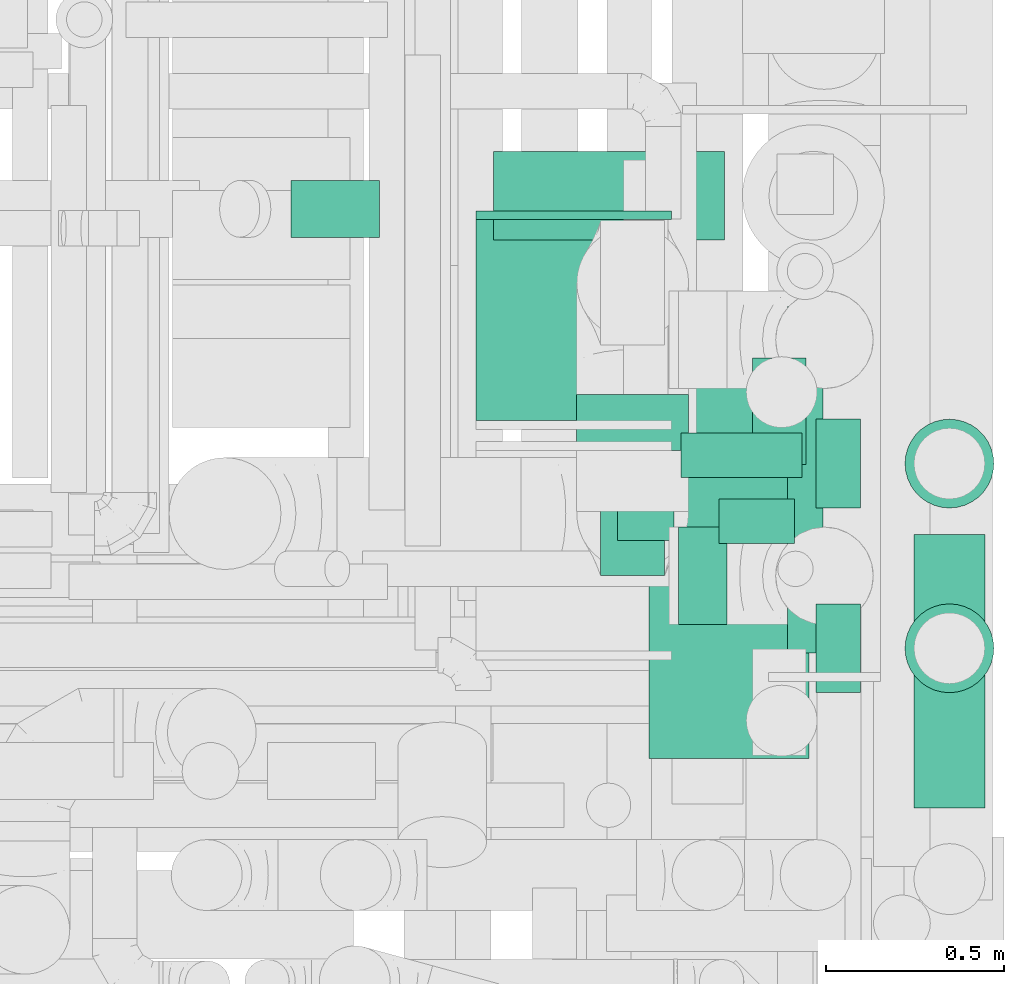
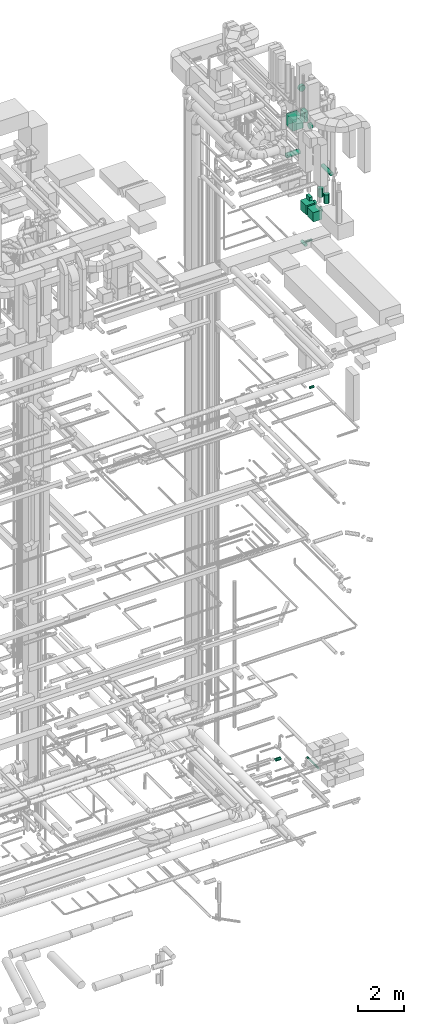
# One storey, part 305 of 337: 18 flow segments, 1 flow fitting.
"""IFC2X3 building model written with IfcOpenShell, lengths in millimetres."""

from ifc_helpers import new_model, entity, si_unit, converted_unit, derived_unit, direction, frame, origin, origin_2d_with_axis, place, context, subcontext, project, spatial, rectangle, circle, extrude, source, transform, mapped, material, type_object, type_shapes, element, save


model = new_model("IFC2X3")

# Units and contexts
model_context = context("Model", 3, precision=0.01, world=origin(), true_north=direction((6.12303176911189e-17, 1.0)))
body_context = subcontext(model_context, "Body", "Model", "MODEL_VIEW")
ifc_project = project(units=[si_unit("LENGTHUNIT", "METRE", prefix="MILLI"), si_unit("AREAUNIT", "SQUARE_METRE"), si_unit("VOLUMEUNIT", "CUBIC_METRE"), converted_unit("PLANEANGLEUNIT", "DEGREE", entity("IfcRatioMeasure", 0.0174532925199433), si_unit("PLANEANGLEUNIT", "RADIAN"), dimensions=[0, 0, 0, 0, 0, 0, 0]), si_unit("MASSUNIT", "GRAM", prefix="KILO"), derived_unit("MASSDENSITYUNIT", [(si_unit("MASSUNIT", "GRAM", prefix="KILO"), 1), (si_unit("LENGTHUNIT", "METRE"), -3)]), derived_unit("MOMENTOFINERTIAUNIT", [(si_unit("LENGTHUNIT", "METRE"), 4)]), si_unit("TIMEUNIT", "SECOND"), si_unit("FREQUENCYUNIT", "HERTZ"), si_unit("THERMODYNAMICTEMPERATUREUNIT", "DEGREE_CELSIUS"), derived_unit("THERMALTRANSMITTANCEUNIT", [(si_unit("MASSUNIT", "GRAM", prefix="KILO"), 1), (si_unit("THERMODYNAMICTEMPERATUREUNIT", "KELVIN"), -1), (si_unit("TIMEUNIT", "SECOND"), -3)]), derived_unit("VOLUMETRICFLOWRATEUNIT", [(si_unit("LENGTHUNIT", "METRE"), 3), (si_unit("TIMEUNIT", "SECOND"), -1)]), derived_unit("MASSFLOWRATEUNIT", [(si_unit("MASSUNIT", "GRAM", prefix="KILO"), 1), (si_unit("TIMEUNIT", "SECOND"), -1)]), derived_unit("ROTATIONALFREQUENCYUNIT", [(si_unit("TIMEUNIT", "SECOND"), -1)]), si_unit("ELECTRICCURRENTUNIT", "AMPERE"), si_unit("ELECTRICVOLTAGEUNIT", "VOLT"), si_unit("POWERUNIT", "WATT"), si_unit("FORCEUNIT", "NEWTON", prefix="KILO"), si_unit("ILLUMINANCEUNIT", "LUX"), si_unit("LUMINOUSFLUXUNIT", "LUMEN"), si_unit("LUMINOUSINTENSITYUNIT", "CANDELA"), derived_unit("USERDEFINED", [(si_unit("MASSUNIT", "GRAM", prefix="KILO"), -1), (si_unit("LENGTHUNIT", "METRE"), -2), (si_unit("TIMEUNIT", "SECOND"), 3), (si_unit("LUMINOUSFLUXUNIT", "LUMEN"), 1)]), derived_unit("LINEARVELOCITYUNIT", [(si_unit("LENGTHUNIT", "METRE"), 1), (si_unit("TIMEUNIT", "SECOND"), -1)]), si_unit("PRESSUREUNIT", "PASCAL"), derived_unit("USERDEFINED", [(si_unit("LENGTHUNIT", "METRE"), -2), (si_unit("MASSUNIT", "GRAM", prefix="KILO"), 1), (si_unit("TIMEUNIT", "SECOND"), -2)]), derived_unit("LINEARFORCEUNIT", [(si_unit("MASSUNIT", "GRAM", prefix="KILO"), 1), (si_unit("LENGTHUNIT", "METRE"), 1), (si_unit("TIMEUNIT", "SECOND"), -2), (si_unit("LENGTHUNIT", "METRE"), -1)]), derived_unit("PLANARFORCEUNIT", [(si_unit("MASSUNIT", "GRAM", prefix="KILO"), 1), (si_unit("LENGTHUNIT", "METRE"), 1), (si_unit("TIMEUNIT", "SECOND"), -2), (si_unit("LENGTHUNIT", "METRE"), -2)])], contexts=[model_context])

# Site, building, storey
site_placement = place(None, origin())
site = spatial("IfcSite", under=ifc_project, at=site_placement, CompositionType="ELEMENT")
building_placement = place(site_placement, origin())
building = spatial("IfcBuilding", under=site, at=building_placement, CompositionType="ELEMENT")
storey_placement = place(building_placement, origin())
storey = spatial("IfcBuildingStorey", under=building, at=storey_placement, CompositionType="ELEMENT", Elevation=0.0)

# Flow segments
duct_segment_type_1 = type_object("IfcDuctSegmentType", PredefinedType="NOTDEFINED")
flow_segment_1_placement = place(storey_placement, frame((72113.11, 10190.65, 33495.0)))
element("IfcFlowSegment", 1, at=flow_segment_1_placement, inside=storey, type_object=duct_segment_type_1, context=body_context, shape_type="SweptSolid", body=[
    extrude(rectangle(XDim=179.999999999994, YDim=350.000000000001, at=origin_2d_with_axis()), frame((90.0, 175.0, 0.0)), (0.0, 0.0, 1.0), 524.999999999989),
])
for number, where in (
    (2, (72249.6, 10288.64, 28450.0)),
    (3, (72249.6, 9676.64, 28450.0)),
):
    element("IfcFlowSegment", number, at=place(storey_placement, frame(where)), inside=storey, type_object=duct_segment_type_1, context=body_context, shape_type="SweptSolid", body=[
        extrude(rectangle(XDim=520.000000000001, YDim=450.000000000002, at=origin_2d_with_axis()), frame((225.0, 260.0, 0.0), z_axis=(0.0, 0.0, 1.0), x_axis=(0.0, -1.0, 0.0)), (0.0, 0.0, 1.0), 499.999999999999),
    ])
flow_segment_2_placement = place(storey_placement, frame((72540.93, 10504.11, 28970.0)))
element("IfcFlowSegment", 4, at=flow_segment_2_placement, inside=storey, type_object=duct_segment_type_1, context=body_context, shape_type="SweptSolid", body=[
    extrude(rectangle(XDim=300.000000000001, YDim=150.000000000001, at=origin_2d_with_axis()), frame((75.0, 150.0, 0.0), z_axis=(0.0, 0.0, 1.0), x_axis=(0.0, 1.0, 0.0)), (0.0, 0.0, 1.0), 179.999999999994),
])
flow_segment_3_placement = place(storey_placement, frame((71761.99, 10628.09, 32875.0)))
element("IfcFlowSegment", 5, at=flow_segment_3_placement, inside=storey, type_object=duct_segment_type_1, context=body_context, shape_type="SweptSolid", body=[
    extrude(rectangle(XDim=564.999999999999, YDim=549.999999999996, at=origin_2d_with_axis()), frame((275.0, 282.5, 0.0), z_axis=(0.0, 0.0, 1.0), x_axis=(0.0, 1.0, 0.0)), (0.0, 0.0, 1.0), 600.000000000002),
])
duct_segment_type_2 = type_object("IfcDuctSegmentType", PredefinedType="NOTDEFINED")
flow_segment_4_placement = place(storey_placement, frame((71240.94, 11141.98, -881.6)))
element("IfcFlowSegment", 6, at=flow_segment_4_placement, inside=storey, type_object=duct_segment_type_2, context=body_context, shape_type="SweptSolid", body=[
    extrude(circle(Radius=80.0, at=origin_2d_with_axis()), frame((0.0, 81.6, 81.6), z_axis=(1.0, 0.0, 0.0), x_axis=(0.0, -1.0, 0.0)), (0.0, 0.0, 1.0), 249.151210282508),
])
flow_segment_5_placement = place(storey_placement, frame((72636.92, 9973.56, -1051.6)))
element("IfcFlowSegment", 7, at=flow_segment_5_placement, inside=storey, type_object=duct_segment_type_2, context=body_context, shape_type="SweptSolid", body=[
    extrude(circle(Radius=50.0, at=origin_2d_with_axis()), frame((51.6, 0.0, 51.6), z_axis=(0.0, 1.0, 0.0), x_axis=(1.0, 0.0, 0.0)), (0.0, 0.0, 1.0), 974.684970000029),
])
flow_segment_6_placement = place(storey_placement, frame((72445.72, 10280.1, 19085.9)))
element("IfcFlowSegment", 8, at=flow_segment_6_placement, inside=storey, type_object=duct_segment_type_2, context=body_context, shape_type="SweptSolid", body=[
    extrude(circle(Radius=62.5, at=origin_2d_with_axis()), frame((0.0, 64.1, 64.1), z_axis=(1.0, 0.0, 0.0), x_axis=(0.0, 1.0, 0.0)), (0.0, 0.0, 1.0), 213.437499999942),
])
flow_segment_7_placement = place(storey_placement, frame((72331.99, 10051.05, 33095.97)))
element("IfcFlowSegment", 9, at=flow_segment_7_placement, inside=storey, type_object=duct_segment_type_2, context=body_context, shape_type="SweptSolid", body=[
    extrude(circle(Radius=137.5, at=origin_2d_with_axis()), frame((0.0, 139.1, 139.1), z_axis=(1.0, 0.0, 0.0), x_axis=(0.0, 1.0, 0.0)), (0.0, 0.0, 1.0), 136.120315571849),
])
flow_segment_8_placement = place(storey_placement, frame((72044.01, 10543.15, 34910.9)))
element("IfcFlowSegment", 10, at=flow_segment_8_placement, inside=storey, type_object=duct_segment_type_2, context=body_context, shape_type="SweptSolid", body=[
    extrude(circle(Radius=157.5, at=origin_2d_with_axis()), frame((159.1, 0.0, 159.1), z_axis=(0.0, 1.0, 0.0), x_axis=(-1.0, 0.0, 0.0)), (0.0, 0.0, 1.0), 157.500000000005),
])
flow_segment_9_placement = place(storey_placement, frame((71811.81, 11133.98, 31073.4)))
element("IfcFlowSegment", 11, at=flow_segment_9_placement, inside=storey, type_object=duct_segment_type_2, context=body_context, shape_type="SweptSolid", body=[
    extrude(circle(Radius=125.0, at=origin_2d_with_axis()), frame((0.0, 126.6, 126.6), z_axis=(1.0, 0.0, 0.0), x_axis=(0.0, 1.0, 0.0)), (0.0, 0.0, 1.0), 650.000000000034),
])
flow_segment_10_placement = place(storey_placement, frame((72993.38, 9536.36, 30698.4)))
element("IfcFlowSegment", 12, at=flow_segment_10_placement, inside=storey, type_object=duct_segment_type_2, context=body_context, shape_type="SweptSolid", body=[
    extrude(circle(Radius=100.0, at=origin_2d_with_axis()), frame((101.6, 0.0, 101.6), z_axis=(0.0, 1.0, 0.0), x_axis=(1.0, 0.0, 0.0)), (0.0, 0.0, 1.0), 770.000000000017),
])
flow_segment_11_placement = place(storey_placement, frame((72968.38, 10379.77, 29040.0)))
element("IfcFlowSegment", 13, at=flow_segment_11_placement, inside=storey, type_object=duct_segment_type_2, context=body_context, shape_type="SweptSolid", body=[
    extrude(circle(Radius=125.0, at=origin_2d_with_axis()), frame((126.6, 126.6, 0.0), z_axis=(0.0, 0.0, 1.0), x_axis=(-1.0, 0.0, 0.0)), (0.0, 0.0, 1.0), 459.999999999999),
])
flow_segment_12_placement = place(storey_placement, frame((72968.38, 9859.77, 29010.0)))
element("IfcFlowSegment", 14, at=flow_segment_12_placement, inside=storey, type_object=duct_segment_type_2, context=body_context, shape_type="SweptSolid", body=[
    extrude(circle(Radius=125.0, at=origin_2d_with_axis()), frame((126.6, 126.6, 0.0), z_axis=(0.0, 0.0, 1.0), x_axis=(-1.0, 0.0, 0.0)), (0.0, 0.0, 1.0), 490.000000000006),
])
flow_segment_13_placement = place(storey_placement, frame((72158.42, 10290.02, 26778.4)))
element("IfcFlowSegment", 15, at=flow_segment_13_placement, inside=storey, type_object=duct_segment_type_2, context=body_context, shape_type="SweptSolid", body=[
    extrude(circle(Radius=80.0, at=origin_2d_with_axis()), frame((81.6, 0.0, 81.6), z_axis=(0.0, 1.0, 0.0), x_axis=(1.0, 0.0, 0.0)), (0.0, 0.0, 1.0), 350.963316826448),
])
flow_segment_14_placement = place(storey_placement, frame((72339.39, 10465.46, 26785.9)))
element("IfcFlowSegment", 16, at=flow_segment_14_placement, inside=storey, type_object=duct_segment_type_2, context=body_context, shape_type="SweptSolid", body=[
    extrude(circle(Radius=62.5, at=origin_2d_with_axis()), frame((0.0, 64.1, 64.1), z_axis=(1.0, 0.0, 0.0), x_axis=(0.0, -1.0, 0.0)), (0.0, 0.0, 1.0), 340.62746066805),
])
for number, where in (
    (17, (72719.6, 9859.77, 28633.4)),
    (18, (72719.6, 10379.77, 28663.4)),
):
    element("IfcFlowSegment", number, at=place(storey_placement, frame(where)), inside=storey, type_object=duct_segment_type_2, context=body_context, shape_type="SweptSolid", body=[
        extrude(circle(Radius=125.0, at=origin_2d_with_axis()), frame((0.0, 126.6, 126.6), z_axis=(1.0, 0.0, 0.0), x_axis=(0.0, 1.0, 0.0)), (0.0, 0.0, 1.0), 125.372808900198),
    ])

# Flow fitting
ifc_material = material()
duct_fitting_type = type_object("IfcDuctFittingType", PredefinedType="NOTDEFINED", material=ifc_material)
shared_shape = source(origin(), body_context, "Body", "SweptSolid", [
    extrude(rectangle(XDim=24.9999999999999, YDim=550.0, at=origin_2d_with_axis()), frame((12.5, 0.0, -300.0)), (0.0, 0.0, 1.0), 600.0),
])
type_shapes(duct_fitting_type, [shared_shape])
flow_fitting_placement = place(storey_placement, frame((72036.99, 11193.09, 33175.0), z_axis=(0.0, 0.0, 1.0), x_axis=(0.0, 1.0, 0.0)))
element("IfcFlowFitting", 19, at=flow_fitting_placement, inside=storey, type_object=duct_fitting_type, material=ifc_material, context=body_context, shape_type="MappedRepresentation", body=[
    mapped(shared_shape, transform((0.0, 0.0, 0.0), scale=1.0)),
])

save(model, "model.ifc")
